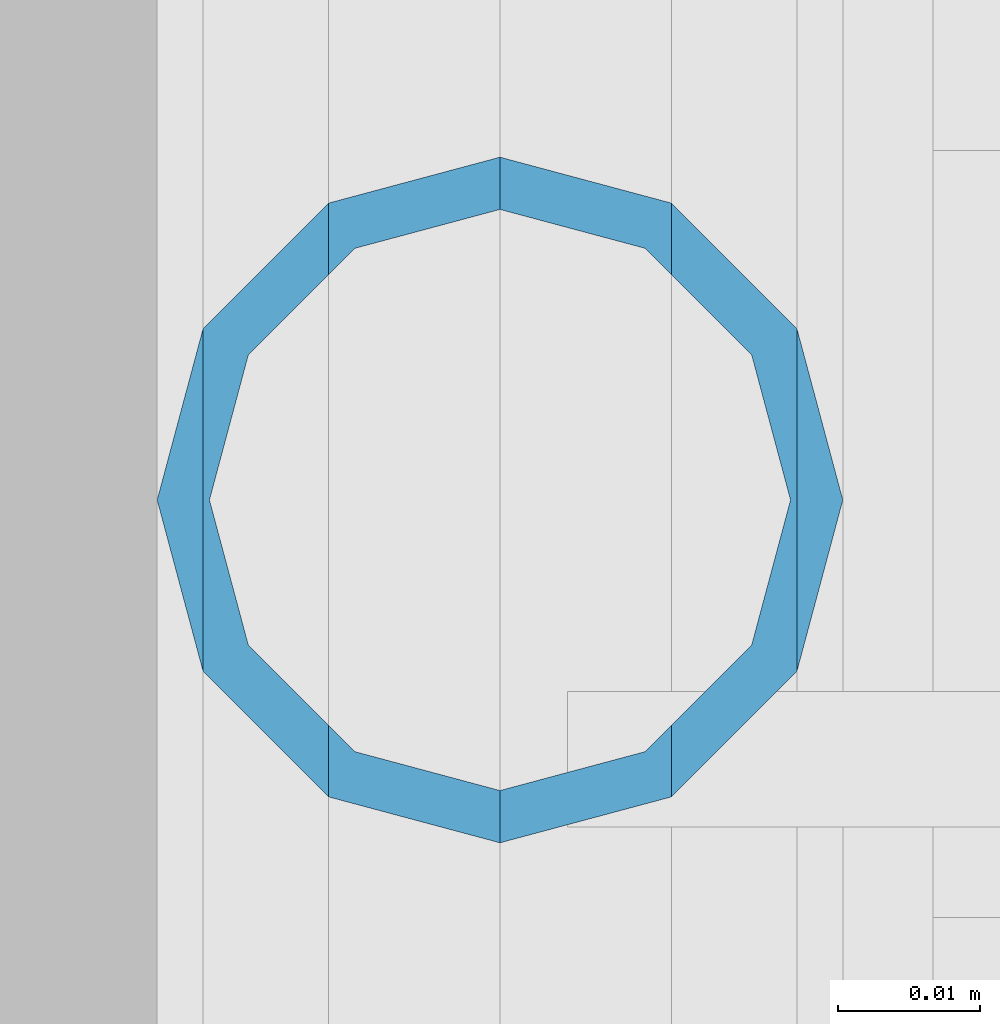
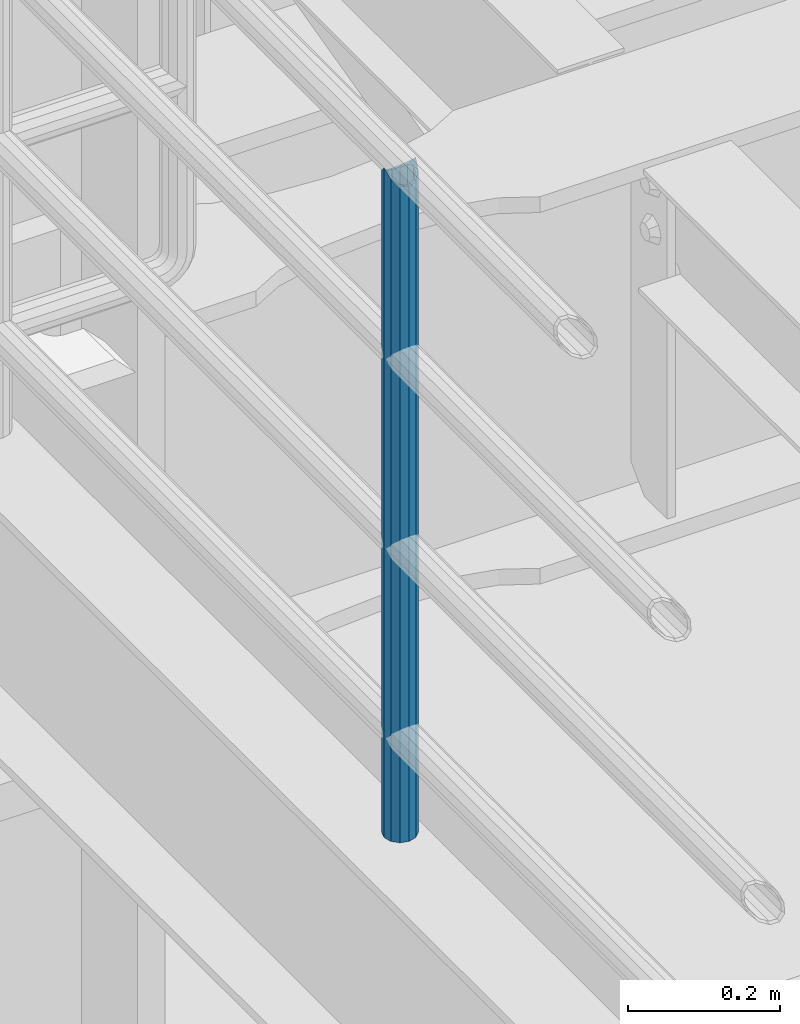
# One storey, part 593 of 1876: 1 column, 1 element without a shape of its own.
"""IFC2X3 building model written with IfcOpenShell, lengths in millimetres."""

import ifcopenshell
import ifcopenshell.guid

model = None  # the IFC model being written
_history = None  # IfcOwnerHistory: only IFC2X3 demands one
_inside = {}  # id of a spatial element -> (the spatial element, [elements in it])
_under = {}  # id of a project, library or spatial element -> (it, [spatial elements below it])
_declared = {}  # id of a project -> (the project, [libraries it declares])
_typed = {}  # id of a type object -> (the type object, [elements of that type])
_made_of = {}  # id of a material, layer set ... -> (it, [elements and type objects made of it])


def new_model(schema):
    """Start an empty IFC model of exactly this schema.

    Asked for "IFC4X3", IfcOpenShell would pick the latest addendum, in which some entities
    have other attributes; the version numbers below select the first issue.
    IFC2X3 requires an IfcOwnerHistory on every rooted entity: one is made here for all.
    """
    global model, _history
    if schema == "IFC4X3":
        model = ifcopenshell.file(schema_version=(4, 3, 0, 0))
    else:
        model = ifcopenshell.file(schema=schema)
    _inside.clear()
    _under.clear()
    _declared.clear()
    _typed.clear()
    _made_of.clear()
    _history = None
    if model.schema == "IFC2X3":
        org = make("IfcOrganization", Name="unknown")
        user = make(
            "IfcPersonAndOrganization",
            ThePerson=make("IfcPerson", FamilyName="unknown"),
            TheOrganization=org,
        )
        app = make(
            "IfcApplication",
            ApplicationDeveloper=org,
            Version="unknown",
            ApplicationFullName="unknown",
            ApplicationIdentifier="unknown",
        )
        _history = make(
            "IfcOwnerHistory",
            OwningUser=user,
            OwningApplication=app,
            ChangeAction="ADDED",
            CreationDate=0,
        )
    return model


def make(cls, **values):
    """One entity of the class cls with the attributes given. An attribute that is None is left unset."""
    return model.create_entity(
        cls, **{name: value for name, value in values.items() if value is not None}
    )


def rooted(cls, **values):
    """An entity with a GlobalId (a new one), such as an element, a storey or a relation."""
    return make(cls, GlobalId=ifcopenshell.guid.new(), OwnerHistory=_history, **values)


def si_unit(unit_type, name, prefix=None):
    """IfcSIUnit, for example si_unit("LENGTHUNIT", "METRE", prefix="MILLI")."""
    return make("IfcSIUnit", UnitType=unit_type, Prefix=prefix, Name=name)


def assignment(units):
    """IfcUnitAssignment: the units of a project."""
    return None if units is None else make("IfcUnitAssignment", Units=units)


def point(xyz):
    """IfcCartesianPoint."""
    return None if xyz is None else make("IfcCartesianPoint", Coordinates=xyz)


def direction(xyz):
    """IfcDirection."""
    return None if xyz is None else make("IfcDirection", DirectionRatios=xyz)


def frame(location, z_axis=None, x_axis=None):
    """IfcAxis2Placement3D, a coordinate frame: its origin and axes. An axis left out is left unset."""
    return make(
        "IfcAxis2Placement3D",
        Location=point(location),
        Axis=direction(z_axis),
        RefDirection=direction(x_axis),
    )


def origin_with_axes():
    """The frame at (0, 0, 0) with the z axis (0, 0, 1) and the x axis (1, 0, 0) written out."""
    return frame((0.0, 0.0, 0.0), z_axis=(0.0, 0.0, 1.0), x_axis=(1.0, 0.0, 0.0))


def place(relative_to, where):
    """IfcLocalPlacement: puts the frame where relative to a parent placement (None: the world)."""
    return make(
        "IfcLocalPlacement", PlacementRelTo=relative_to, RelativePlacement=where
    )


def context(
    kind, dimensions, precision=None, world=None, true_north=None, identifier=None
):
    """IfcGeometricRepresentationContext, for example the 3D "Model" context."""
    return make(
        "IfcGeometricRepresentationContext",
        ContextIdentifier=identifier,
        ContextType=kind,
        CoordinateSpaceDimension=dimensions,
        Precision=precision,
        WorldCoordinateSystem=world,
        TrueNorth=true_north,
    )


def subcontext(parent, identifier, kind, view, scale=None):
    """IfcGeometricRepresentationSubContext, for example "Body" below "Model"."""
    return make(
        "IfcGeometricRepresentationSubContext",
        ContextIdentifier=identifier,
        ContextType=kind,
        ParentContext=parent,
        TargetScale=scale,
        TargetView=view,
    )


def project(units=None, contexts=None):
    """IfcProject with its units and contexts."""
    return rooted(
        "IfcProject",
        Name="project",
        RepresentationContexts=contexts,
        UnitsInContext=assignment(units),
    )


def spatial(cls, under=None, at=None, **own):
    """A site, building, storey or space (cls), placed at a placement, below another one or the project."""
    s = rooted(cls, ObjectPlacement=at, **own)
    if under is not None:
        _under.setdefault(under.id(), (under, []))[1].append(s)
    return s


def faces_of(points, faces, orient=None, outer=None):
    """IfcFace entities. A face is a list of loops; a loop is a list of indices into points, from 0.

    orient and outer hold one flag for each loop. By default every Orientation is true, the
    first loop of a face is its IfcFaceOuterBound and the others are IfcFaceBound.
    """
    made = []
    for i, loops in enumerate(faces):
        bounds = []
        for j, loop in enumerate(loops):
            is_outer = j == 0 if outer is None else outer[i][j]
            bounds.append(
                make(
                    "IfcFaceOuterBound" if is_outer else "IfcFaceBound",
                    Bound=make("IfcPolyLoop", Polygon=[points[k] for k in loop]),
                    Orientation=True if orient is None else orient[i][j],
                )
            )
        made.append(make("IfcFace", Bounds=bounds))
    return made


def faceted_brep(points, faces, orient=None, outer=None, voids=None):
    """IfcFacetedBrep: a solid bounded by flat faces; with voids (closed shells), ...WithVoids."""
    shared = [point(p) for p in points]
    hull = make("IfcClosedShell", CfsFaces=faces_of(shared, faces, orient, outer))
    if voids is None:
        return make("IfcFacetedBrep", Outer=hull)
    return make(
        "IfcFacetedBrepWithVoids",
        Outer=hull,
        Voids=[
            make(cls, CfsFaces=faces_of(shared, fs, o, b)) for cls, fs, o, b in voids
        ],
    )


def shape(context_of_items, identifier, shape_type, items):
    """IfcShapeRepresentation: the items that make up one representation, for example the "Body"."""
    return make(
        "IfcShapeRepresentation",
        ContextOfItems=context_of_items,
        RepresentationIdentifier=identifier,
        RepresentationType=shape_type,
        Items=items,
    )


def material(Name=None, Category=None):
    """IfcMaterial."""
    return make("IfcMaterial", Name=Name, Category=Category)


def made_of(thing, what):
    """Note that an element or type object is made of a material, layer set ...; save() writes the relation."""
    if what is not None:
        _made_of.setdefault(what.id(), (what, []))[1].append(thing)
    return thing


def type_object(cls, material=None, **own):
    """A type object (cls), such as IfcWallType, which elements share."""
    return made_of(rooted(cls, **own), material)


def element(
    cls,
    number,
    at=None,
    inside=None,
    cuts=None,
    type_object=None,
    material=None,
    context=None,
    identifier="Body",
    shape_type=None,
    held_by="IfcProductDefinitionShape",
    body=None,
    shapes=None,
    **own,
):
    """One element of the class cls, such as IfcWall. Its Tag is "e" and its number.

    at: its placement. inside: the storey or other place that contains it. cuts: it is an
    opening in that element (IfcRelVoidsElement). A single representation is given by context,
    identifier, shape_type and body (its items); several are given by shapes. held_by: the class
    of the entity that holds the representations. save() writes the other relations.
    """
    e = rooted(cls, Tag="e%d" % number, ObjectPlacement=at, **own)
    if body is not None:
        shapes = [shape(context, identifier, shape_type, body)]
    if shapes is not None:
        e.Representation = make(held_by, Representations=shapes)
    if inside is not None:
        _inside.setdefault(inside.id(), (inside, []))[1].append(e)
    if cuts is not None:
        rooted(
            "IfcRelVoidsElement", RelatingBuildingElement=cuts, RelatedOpeningElement=e
        )
    if type_object is not None:
        _typed.setdefault(type_object.id(), (type_object, []))[1].append(e)
    return made_of(e, material)


def aggregate(whole, parts):
    """IfcRelAggregates: a whole, such as a stair, and the parts it consists of."""
    return rooted("IfcRelAggregates", RelatingObject=whole, RelatedObjects=parts)


def save(model, path):
    """Write the relations noted so far, then the file.

    IfcRelAggregates (storeys below a building ...), IfcRelContainedInSpatialStructure (elements
    in a storey), IfcRelDefinesByType, IfcRelAssociatesMaterial and IfcRelDeclares: one each for
    every whole, place, type object, material and project.
    """
    for whole, parts in _under.values():
        aggregate(whole, parts)
    for where, things in _inside.values():
        rooted(
            "IfcRelContainedInSpatialStructure",
            RelatedElements=things,
            RelatingStructure=where,
        )
    for kind, things in _typed.values():
        rooted("IfcRelDefinesByType", RelatedObjects=things, RelatingType=kind)
    for what, things in _made_of.values():
        rooted("IfcRelAssociatesMaterial", RelatedObjects=things, RelatingMaterial=what)
    for by, libraries in _declared.values():
        rooted("IfcRelDeclares", RelatingContext=by, RelatedDefinitions=libraries)
    model.write(path)


model = new_model("IFC2X3")

# Units and contexts
model_context = context("Model", 3, precision=1e-05, world=origin_with_axes())
body_context = subcontext(model_context, "Body", "Model", "MODEL_VIEW")
ifc_project = project(units=[si_unit("LENGTHUNIT", "METRE", prefix="MILLI"), si_unit("AREAUNIT", "SQUARE_METRE"), si_unit("VOLUMEUNIT", "CUBIC_METRE"), si_unit("MASSUNIT", "GRAM", prefix="KILO"), si_unit("TIMEUNIT", "SECOND"), si_unit("PLANEANGLEUNIT", "RADIAN"), si_unit("SOLIDANGLEUNIT", "STERADIAN"), si_unit("THERMODYNAMICTEMPERATUREUNIT", "DEGREE_CELSIUS"), si_unit("LUMINOUSINTENSITYUNIT", "LUMEN")], contexts=[model_context])

# Site, building, storey
site_placement = place(None, origin_with_axes())
site = spatial("IfcSite", under=ifc_project, at=site_placement, CompositionType="ELEMENT")
building_placement = place(site_placement, origin_with_axes())
building = spatial("IfcBuilding", under=site, at=building_placement, Name="Undefined", CompositionType="ELEMENT")
storey_placement = place(building_placement, origin_with_axes())
storey = spatial("IfcBuildingStorey", under=building, at=storey_placement, Name="Undefined", CompositionType="ELEMENT", Elevation=0.0)

# Assembly, column
assembly_placement = place(storey_placement, origin_with_axes())
assembly = element("IfcElementAssembly", 1, at=assembly_placement, inside=storey, Name="RAIL", AssemblyPlace="NOTDEFINED", PredefinedType="RIGID_FRAME")
ifc_material = material()
column_type = type_object("IfcColumnType", Name="PIPE1-1/2SCH40", PredefinedType="NOTDEFINED")
column_placement = place(assembly_placement, frame((6.3664629124105e-12, -5857.08125, 17983.2), z_axis=(0.0, 1.0, 0.0), x_axis=(0.0, 0.0, 1.0)))
column = element("IfcColumn", 2, at=column_placement, type_object=column_type, material=ifc_material, Name="POST", ObjectType="PIPE1-1/2SCH40", context=body_context, shape_type="Brep", body=[
    faceted_brep([(1055.42780700668, -12.0650000000001, 20.8971929933186), (1055.42780700668, -12.0650000000001, 15.8661214311805), (1054.93437856882, -10.2235000000001, 17.7076214311801), (1052.195, 0.0, 20.4470000000001), (1052.195, 0.0, 24.1300000000001), (1054.93437856882, 10.2235000000001, 17.7076214311801), (1055.42780700668, 12.0650000000001, 15.8661214311805), (1055.42780700668, 12.0650000000001, 20.8971929933186), (1076.325, 24.1300000000001, 0.0), (1064.26, 20.8971929933184, 12.0649999999996), (1064.25999999999, 20.8971929933186, -12.0649999999996), (1061.07042843786, 17.7076214311803, 10.2235000000001), (1063.80980700668, 20.4469999999999, 0.0), (1061.07042843786, 17.7076214311803, -10.2235000000001), (1055.42780700668, 12.0650000000001, -15.8661214311805), (1055.42780700667, 12.0649999999996, -20.8971929933186), (1054.93437856882, 10.2235000000001, -17.7076214311801), (1052.195, 0.0, -20.4470000000001), (1052.19499999999, 0.0, -24.1300000000001), (1055.42780700668, -12.0650000000001, -15.8661214311805), (1055.42780700667, -12.0649999999996, -20.8971929933186), (1054.93437856882, -10.2235000000001, -17.7076214311801), (1076.325, -24.1300000000001, 0.0), (1064.25999999999, -20.8971929933186, -12.0649999999996), (1064.26, -20.8971929933184, 12.0649999999996), (1061.07042843786, -17.7076214311803, -10.2235000000001), (1063.80980700668, -20.4469999999999, 0.0), (1061.07042843786, -17.7076214311803, 10.2235000000001), (0.0, -20.8971929933184, -12.0649999999996), (0.0, -12.0650000000001, -20.8971929933186), (-1.45519152283669e-11, 0.0, -24.130000000001), (0.0, 12.0650000000001, -20.8971929933186), (0.0, 20.8971929933184, -12.0649999999996), (0.0, 24.1299999999992, 0.0), (0.0, 20.8971929933184, 12.0649999999996), (0.0, 12.0650000000001, 20.8971929933186), (-1.45519152283669e-11, 0.0, 24.130000000001), (0.0, -12.0650000000001, 20.8971929933186), (0.0, -20.8971929933184, 12.0649999999996), (0.0, -24.1299999999992, 0.0), (0.0, -17.7076214311803, -10.2235000000001), (0.0, -10.2235000000001, -17.7076214311801), (-1.45519152283669e-11, 0.0, -20.4470000000001), (0.0, 10.2235000000001, -17.7076214311801), (0.0, 17.7076214311803, -10.2235000000001), (0.0, 20.4469999999999, 0.0), (0.0, 17.7076214311803, 10.2235000000001), (0.0, 10.2235000000001, 17.7076214311801), (-1.45519152283669e-11, 0.0, 20.4470000000001), (0.0, -10.2235000000001, 17.7076214311801), (0.0, -17.7076214311803, 10.2235000000001), (0.0, -20.4469999999999, 0.0)], [[[0, 1, 2, 3, 4]], [[4, 3, 5, 6, 7]], [[8, 9, 10]], [[7, 6, 11, 12, 13, 14, 15, 10, 9]], [[16, 17, 18, 15, 14]], [[19, 20, 18, 17, 21]], [[22, 23, 24]], [[24, 23, 20, 19, 25, 26, 27, 1, 0]], [[28, 29, 20, 23]], [[29, 30, 18, 20]], [[30, 31, 15, 18]], [[31, 32, 10, 15]], [[32, 33, 8, 10]], [[33, 34, 9, 8]], [[34, 35, 7, 9]], [[35, 36, 4, 7]], [[36, 37, 0, 4]], [[37, 38, 24, 0]], [[38, 39, 22, 24]], [[39, 28, 23, 22]], [[38, 37, 36, 35, 34, 33, 32, 31, 30, 29, 28, 39], [40, 41, 42, 43, 44, 45, 46, 47, 48, 49, 50, 51]], [[40, 51, 26, 25]], [[21, 41, 40, 25, 19]], [[42, 41, 21, 17]], [[43, 42, 17, 16]], [[44, 43, 16, 14, 13]], [[45, 44, 13, 12]], [[46, 45, 12, 11]], [[5, 47, 46, 11, 6]], [[48, 47, 5, 3]], [[49, 48, 3, 2]], [[50, 49, 2, 1, 27]], [[51, 50, 27, 26]]]),
])
aggregate(assembly, [column])

save(model, "model.ifc")
